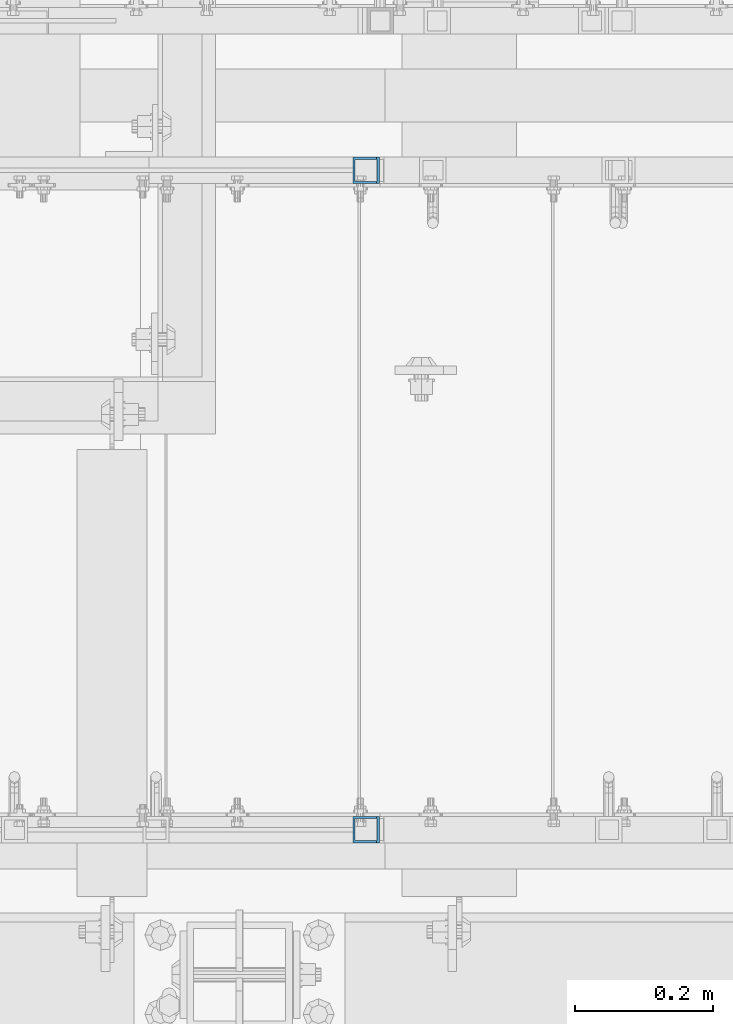
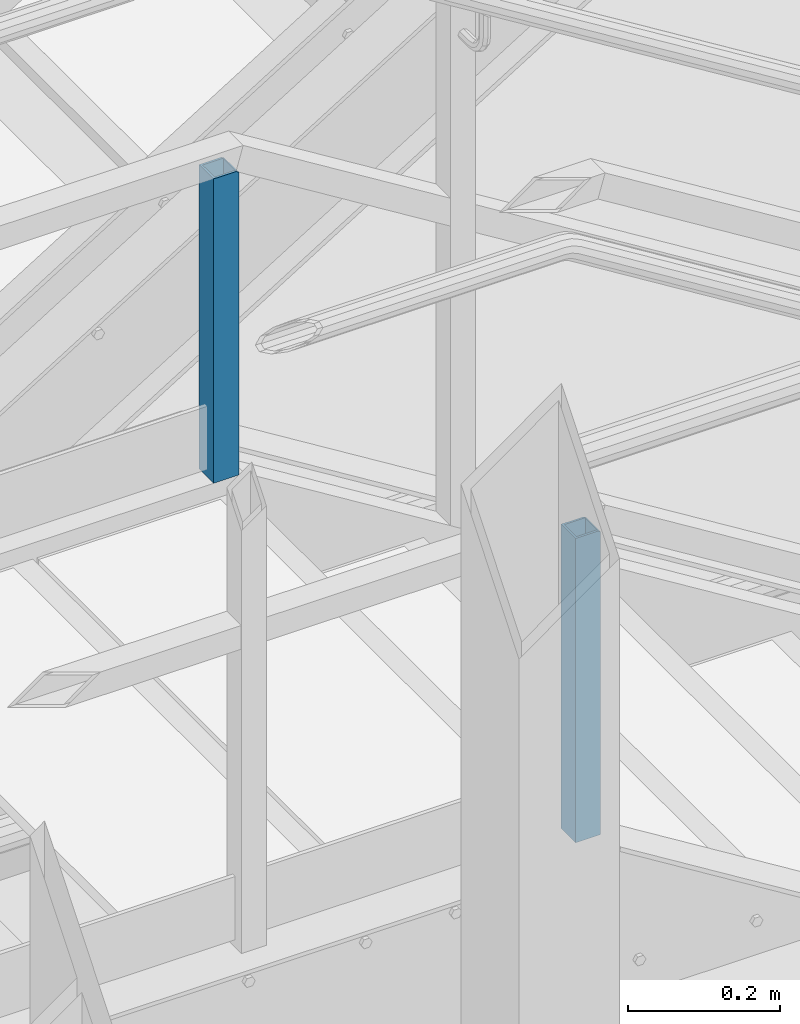
# One storey, part 805 of 1876: 2 columns, 2 elements without a shape of their own.
"""IFC2X3 building model written with IfcOpenShell, lengths in millimetres."""

from ifc_helpers import new_model, si_unit, frame, origin_with_axes, place, context, subcontext, project, spatial, faceted_brep, material, type_object, element, aggregate, save


model = new_model("IFC2X3")

# Units and contexts
model_context = context("Model", 3, precision=1e-05, world=origin_with_axes())
body_context = subcontext(model_context, "Body", "Model", "MODEL_VIEW")
ifc_project = project(units=[si_unit("LENGTHUNIT", "METRE", prefix="MILLI"), si_unit("AREAUNIT", "SQUARE_METRE"), si_unit("VOLUMEUNIT", "CUBIC_METRE"), si_unit("MASSUNIT", "GRAM", prefix="KILO"), si_unit("TIMEUNIT", "SECOND"), si_unit("PLANEANGLEUNIT", "RADIAN"), si_unit("SOLIDANGLEUNIT", "STERADIAN"), si_unit("THERMODYNAMICTEMPERATUREUNIT", "DEGREE_CELSIUS"), si_unit("LUMINOUSINTENSITYUNIT", "LUMEN")], contexts=[model_context])

# Site, building, storey
site_placement = place(None, origin_with_axes())
site = spatial("IfcSite", under=ifc_project, at=site_placement, CompositionType="ELEMENT")
building_placement = place(site_placement, origin_with_axes())
building = spatial("IfcBuilding", under=site, at=building_placement, Name="Undefined", CompositionType="ELEMENT")
storey_placement = place(building_placement, origin_with_axes())
storey = spatial("IfcBuildingStorey", under=building, at=storey_placement, Name="Undefined", CompositionType="ELEMENT", Elevation=0.0)

# Assembly, column
assembly_1_placement = place(storey_placement, origin_with_axes())
assembly_1 = element("IfcElementAssembly", 1, at=assembly_1_placement, inside=storey, Name="RAIL", AssemblyPlace="NOTDEFINED", PredefinedType="RIGID_FRAME")
ifc_material = material()
column_type = type_object("IfcColumnType", Name="HSS1-1/2X1-1/2X1/8", PredefinedType="NOTDEFINED")
column_1_placement = place(assembly_1_placement, frame((2722.88000091923, -5949.95000191373, 15594.7768518519), z_axis=(-1.0, 0.0, 0.0), x_axis=(0.0, 0.0, 1.0)))
column_1 = element("IfcColumn", 2, at=column_1_placement, type_object=column_type, material=ifc_material, Name="RAIL", ObjectType="HSS1-1/2X1-1/2X1/8", context=body_context, shape_type="Brep", body=[
    faceted_brep([(488.949999519229, -19.0499992349996, -14.8974586793274), (486.377450375128, -19.0499992349996, -19.0499992349951), (486.377450375128, 19.0499992349996, -19.0499992349951), (488.950003786911, 19.0499992349996, -14.8974586793274), (488.950003786911, 15.8749992829999, -14.8974586793274), (488.34440126751, 15.8749992829999, -15.8749992829948), (488.34440126751, -15.8749992829999, -15.8749992829948), (488.950003786911, -15.8749992829999, -14.8974586793274), (488.950003786924, 15.8749992829999, 15.8749992830049), (5.45696821063757e-12, 15.8749992829999, 15.8749992829999), (-7.27595761418343e-12, 15.8749992829999, -15.8749992829999), (5.45696821063757e-12, -15.8749992829999, 15.8749992829999), (488.950003786924, -15.8749992829999, 15.8749992830049), (-7.27595761418343e-12, -15.8749992829999, -15.8749992829999), (0.0, -19.0499992349996, -19.0499992350001), (0.0, -19.0499992349996, 19.0499992349996), (0.0, 19.0499992349996, 19.0499992349996), (0.0, 19.0499992349996, -19.0499992350001), (488.950003786926, -19.0499992349996, 19.0499992350051), (488.950003786926, 19.0499992349996, 19.0499992350051)], [[[0, 1, 2, 3, 4, 5, 6, 7]], [[8, 9, 10, 5, 4]], [[11, 9, 8, 12]], [[13, 11, 12, 7, 6]], [[10, 13, 6, 5]], [[14, 15, 16, 17], [9, 11, 13, 10]], [[16, 15, 18, 19]], [[12, 8, 4, 3, 19, 18, 0, 7]], [[17, 16, 19, 3, 2]], [[14, 17, 2, 1]], [[18, 15, 14, 1, 0]]]),
])
aggregate(assembly_1, [column_1])

assembly_2_placement = place(storey_placement, origin_with_axes())
assembly_2 = element("IfcElementAssembly", 3, at=assembly_2_placement, inside=storey, Name="RAIL", AssemblyPlace="NOTDEFINED", PredefinedType="RIGID_FRAME")
column_2_placement = place(assembly_2_placement, frame((2722.88000091923, -6902.45000191595, 15594.7768518808), z_axis=(-1.0, 0.0, 0.0), x_axis=(0.0, 0.0, 1.0)))
column_2 = element("IfcColumn", 4, at=column_2_placement, type_object=column_type, material=ifc_material, Name="RAIL", ObjectType="HSS1-1/2X1-1/2X1/8", context=body_context, shape_type="Brep", body=[
    faceted_brep([(488.949999519229, -19.0499992349996, -14.8974586793274), (486.377450375128, -19.0499992349996, -19.0499992349951), (486.377450375128, 19.0499992349996, -19.0499992349951), (488.950003786911, 19.0499992349996, -14.8974586793274), (488.950003786911, 15.8749992829999, -14.8974586793274), (488.34440126751, 15.8749992829999, -15.8749992829948), (488.34440126751, -15.8749992829999, -15.8749992829948), (488.950003786911, -15.8749992829999, -14.8974586793274), (488.950003786924, 15.8749992829999, 15.8749992830049), (5.45696821063757e-12, 15.8749992829999, 15.8749992829999), (-7.27595761418343e-12, 15.8749992829999, -15.8749992829999), (5.45696821063757e-12, -15.8749992829999, 15.8749992829999), (488.950003786924, -15.8749992829999, 15.8749992830049), (-7.27595761418343e-12, -15.8749992829999, -15.8749992829999), (0.0, -19.0499992349996, -19.0499992350001), (0.0, -19.0499992349996, 19.0499992349996), (0.0, 19.0499992349996, 19.0499992349996), (0.0, 19.0499992349996, -19.0499992350001), (488.950003786926, -19.0499992349996, 19.0499992350051), (488.950003786926, 19.0499992349996, 19.0499992350051)], [[[0, 1, 2, 3, 4, 5, 6, 7]], [[8, 9, 10, 5, 4]], [[11, 9, 8, 12]], [[13, 11, 12, 7, 6]], [[10, 13, 6, 5]], [[14, 15, 16, 17], [9, 11, 13, 10]], [[16, 15, 18, 19]], [[12, 8, 4, 3, 19, 18, 0, 7]], [[17, 16, 19, 3, 2]], [[14, 17, 2, 1]], [[18, 15, 14, 1, 0]]]),
])
aggregate(assembly_2, [column_2])

save(model, "model.ifc")
